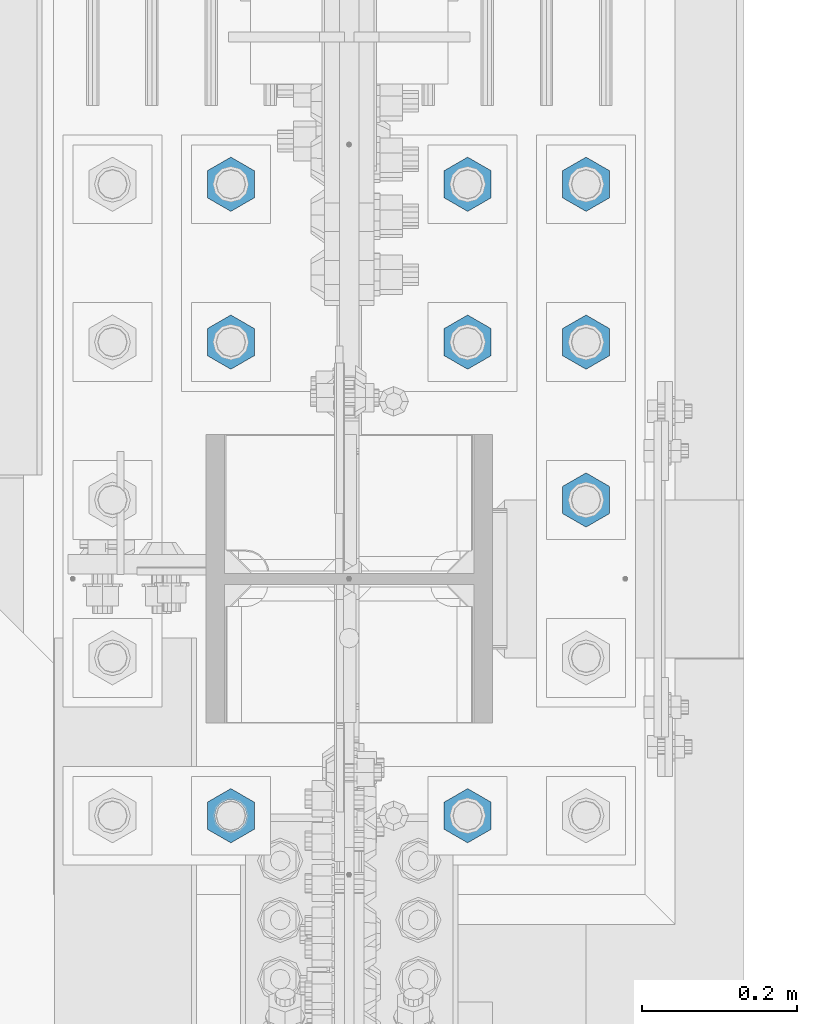
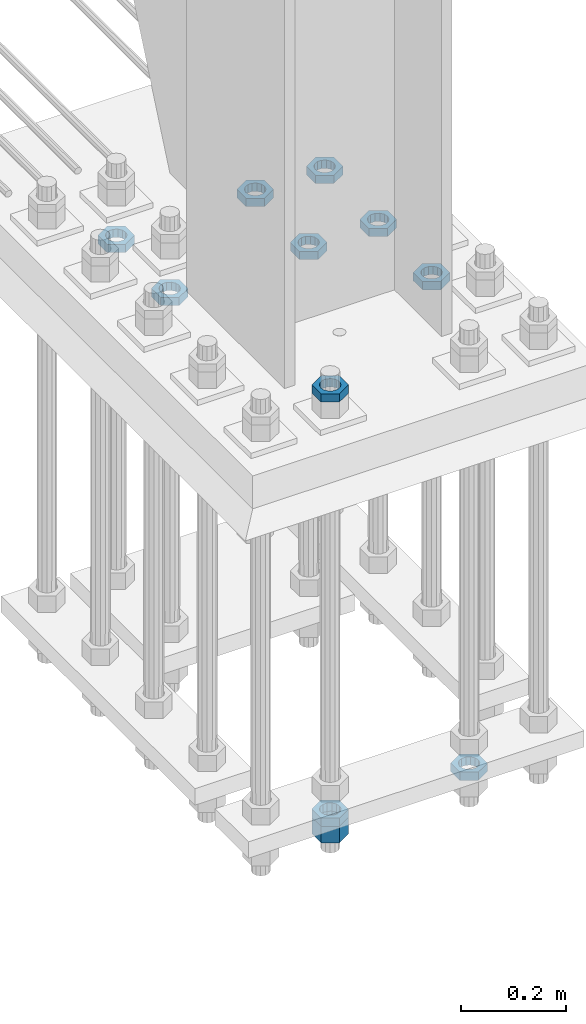
# One storey, part 2955 of 3843: 11 beams, 1 element without a shape of its own.
"""IFC2X3 building model written with IfcOpenShell, lengths in millimetres."""

from ifc_helpers import new_model, si_unit, frame, origin_with_axes, place, context, subcontext, project, spatial, faceted_brep, material, type_object, element, aggregate, save


model = new_model("IFC2X3")

# Units and contexts
model_context = context("Model", 3, precision=1e-05, world=origin_with_axes())
body_context = subcontext(model_context, "Body", "Model", "MODEL_VIEW")
ifc_project = project(units=[si_unit("LENGTHUNIT", "METRE", prefix="MILLI"), si_unit("AREAUNIT", "SQUARE_METRE"), si_unit("VOLUMEUNIT", "CUBIC_METRE"), si_unit("MASSUNIT", "GRAM", prefix="KILO"), si_unit("TIMEUNIT", "SECOND"), si_unit("PLANEANGLEUNIT", "RADIAN"), si_unit("SOLIDANGLEUNIT", "STERADIAN"), si_unit("THERMODYNAMICTEMPERATUREUNIT", "DEGREE_CELSIUS"), si_unit("LUMINOUSINTENSITYUNIT", "LUMEN")], contexts=[model_context])

# Site, building, storey
site_placement = place(None, origin_with_axes())
site = spatial("IfcSite", under=ifc_project, at=site_placement, CompositionType="ELEMENT")
building_placement = place(site_placement, origin_with_axes())
building = spatial("IfcBuilding", under=site, at=building_placement, Name="Undefined", CompositionType="ELEMENT")
storey_placement = place(building_placement, origin_with_axes())
storey = spatial("IfcBuildingStorey", under=building, at=storey_placement, Name="Undefined", CompositionType="ELEMENT", Elevation=0.0)

# Assembly, beams
assembly_placement = place(storey_placement, origin_with_axes())
assembly = element("IfcElementAssembly", 1, at=assembly_placement, inside=storey, Name="TEMPLATE", AssemblyPlace="NOTDEFINED", PredefinedType="RIGID_FRAME")
ifc_material = material(Name="STEEL/A572-50")
beam_type_1 = type_object("IfcBeamType", Name="1-1/2_HEAVY_HEX_NUT", PredefinedType="NOTDEFINED")
beam_1_placement = place(assembly_placement, frame((85496.4, 91909.9, 28746.4500015259), z_axis=(1.0, 0.0, 0.0), x_axis=(0.0, 0.0, -1.0)))
beam_1 = element("IfcBeam", 2, at=beam_1_placement, type_object=beam_type_1, material=ifc_material, Name="NUT", ObjectType="1-1/2_HEAVY_HEX_NUT", context=body_context, shape_type="Brep", body=[
    faceted_brep([(0.0, -34.9199981689453, 0.0), (0.0, -17.4599990844727, -30.25), (38.0999999999985, -17.4599990844727, -30.25), (38.0999999999985, -34.9199981689453, 0.0), (0.0, 17.4599990844727, -30.25), (38.0999999999985, 17.4599990844727, -30.25), (0.0, 34.9199981689453, 0.0), (38.0999999999985, 34.9199981689453, 0.0), (0.0, 17.4599990844727, 30.25), (38.0999999999985, 17.4599990844727, 30.25), (0.0, -17.4599990844727, 30.25), (38.0999999999985, -17.4599990844727, 30.25), (0.0, 0.0, 20.6399993896484), (0.0, 8.9553601105581, 18.5959968835959), (38.0999999999985, 8.9553601105581, 18.5959968835959), (38.0999999999985, 0.0, 20.6399993896484), (0.0, 16.1370013209525, 12.8688291298167), (38.0999999999985, 16.1370013209525, 12.8688291298167), (0.0, 20.1225115123816, 4.59283194104501), (38.0999999999985, 20.1225115123816, 4.59283194104501), (0.0, 20.1225115123816, -4.59283194104501), (38.0999999999985, 20.1225115123816, -4.59283194104501), (0.0, 16.1370013209525, -12.8688291298167), (38.0999999999985, 16.1370013209525, -12.8688291298167), (0.0, 8.9553601105581, -18.5959968835959), (38.0999999999985, 8.9553601105581, -18.5959968835959), (0.0, 0.0, -20.6399993896484), (38.0999999999985, 0.0, -20.6399993896484), (0.0, -8.9553601105581, -18.5959968835959), (38.0999999999985, -8.9553601105581, -18.5959968835959), (0.0, -16.1370013209525, -12.8688291298167), (38.0999999999985, -16.1370013209525, -12.8688291298167), (0.0, -20.1225115123816, -4.59283194104501), (38.0999999999985, -20.1225115123816, -4.59283194104501), (0.0, -20.1225115123816, 4.59283194104501), (38.0999999999985, -20.1225115123816, 4.59283194104501), (0.0, -16.1370013209525, 12.8688291298167), (38.0999999999985, -16.1370013209525, 12.8688291298167), (0.0, -8.9553601105581, 18.5959968835959), (38.0999999999985, -8.9553601105581, 18.5959968835959)], [[[0, 1, 2, 3]], [[1, 4, 5, 2]], [[4, 6, 7, 5]], [[6, 8, 9, 7]], [[8, 10, 11, 9]], [[10, 0, 3, 11]], [[12, 13, 14, 15]], [[13, 16, 17, 14]], [[16, 18, 19, 17]], [[18, 20, 21, 19]], [[20, 22, 23, 21]], [[22, 24, 25, 23]], [[24, 26, 27, 25]], [[26, 28, 29, 27]], [[28, 30, 31, 29]], [[30, 32, 33, 31]], [[32, 34, 35, 33]], [[34, 36, 37, 35]], [[36, 38, 39, 37]], [[38, 12, 15, 39]], [[5, 7, 9, 11, 3, 2], [17, 19, 21, 23, 25, 27, 29, 31, 33, 35, 37, 39, 15, 14]], [[10, 8, 6, 4, 1, 0], [38, 36, 34, 32, 30, 28, 26, 24, 22, 20, 18, 16, 13, 12]]]),
])
beam_type_2 = type_object("IfcBeamType", Name="1-1/2_HALF_NUT", PredefinedType="NOTDEFINED")
beam_2_placement = place(assembly_placement, frame((85953.5999938965, 92316.3, 29603.7), z_axis=(1.0, 0.0, 0.0), x_axis=(0.0, 0.0, -1.0)))
beam_2 = element("IfcBeam", 3, at=beam_2_placement, type_object=beam_type_2, material=ifc_material, Name="NUT", ObjectType="1-1/2_HALF_NUT", context=body_context, shape_type="Brep", body=[
    faceted_brep([(0.0, -34.9199981689453, 0.0), (0.0, -17.4599990844727, -30.25), (19.0500000000029, -17.4599990844727, -30.25), (19.0500000000029, -34.9199981689453, 0.0), (0.0, 17.4599990844727, -30.25), (19.0500000000029, 17.4599990844727, -30.25), (0.0, 34.9199981689453, 0.0), (19.0500000000029, 34.9199981689453, 0.0), (0.0, 17.4599990844727, 30.25), (19.0500000000029, 17.4599990844727, 30.25), (0.0, -17.4599990844727, 30.25), (19.0500000000029, -17.4599990844727, 30.25), (0.0, 0.0, 20.6399993896484), (0.0, 8.9553601105581, 18.5959968835959), (19.0500000000029, 8.95536011056538, 18.5959968835959), (19.0500000000029, 0.0, 20.6399993896484), (0.0, 16.1370013209525, 12.8688291298167), (19.0500000000029, 16.1370013209489, 12.8688291298167), (0.0, 20.1225115123816, 4.59283194104501), (19.0500000000029, 20.1225115123852, 4.59283194104501), (0.0, 20.1225115123816, -4.59283194104501), (19.0500000000029, 20.1225115123852, -4.59283194104501), (0.0, 16.1370013209525, -12.8688291298167), (19.0500000000029, 16.1370013209489, -12.8688291298167), (0.0, 8.9553601105581, -18.5959968835959), (19.0500000000029, 8.95536011056538, -18.5959968835959), (0.0, 0.0, -20.6399993896484), (19.0500000000029, 0.0, -20.6399993896484), (0.0, -8.9553601105581, -18.5959968835959), (19.0500000000029, -8.95536011056538, -18.5959968835959), (0.0, -16.1370013209525, -12.8688291298167), (19.0500000000029, -16.1370013209489, -12.8688291298167), (0.0, -20.1225115123816, -4.59283194104501), (19.0500000000029, -20.1225115123852, -4.59283194104501), (0.0, -20.1225115123816, 4.59283194104501), (19.0500000000029, -20.1225115123852, 4.59283194104501), (0.0, -16.1370013209525, 12.8688291298167), (19.0500000000029, -16.1370013209489, 12.8688291298167), (0.0, -8.9553601105581, 18.5959968835959), (19.0500000000029, -8.95536011056538, 18.5959968835959)], [[[0, 1, 2, 3]], [[1, 4, 5, 2]], [[4, 6, 7, 5]], [[6, 8, 9, 7]], [[8, 10, 11, 9]], [[10, 0, 3, 11]], [[12, 13, 14, 15]], [[13, 16, 17, 14]], [[16, 18, 19, 17]], [[18, 20, 21, 19]], [[20, 22, 23, 21]], [[22, 24, 25, 23]], [[24, 26, 27, 25]], [[26, 28, 29, 27]], [[28, 30, 31, 29]], [[30, 32, 33, 31]], [[32, 34, 35, 33]], [[34, 36, 37, 35]], [[36, 38, 39, 37]], [[38, 12, 15, 39]], [[5, 7, 9, 11, 3, 2], [17, 19, 21, 23, 25, 27, 29, 31, 33, 35, 37, 39, 15, 14]], [[10, 8, 6, 4, 1, 0], [38, 36, 34, 32, 30, 28, 26, 24, 22, 20, 18, 16, 13, 12]]]),
])
beam_3_placement = place(assembly_placement, frame((85953.5999938965, 92519.5, 29603.7), z_axis=(-1.0, 0.0, 0.0), x_axis=(0.0, 0.0, -1.0)))
beam_3 = element("IfcBeam", 4, at=beam_3_placement, type_object=beam_type_2, material=ifc_material, Name="NUT", ObjectType="1-1/2_HALF_NUT", context=body_context, shape_type="Brep", body=[
    faceted_brep([(0.0, -34.9199981689453, 0.0), (0.0, -17.4599990844727, -30.25), (19.0500000000029, -17.4599990844727, -30.25), (19.0500000000029, -34.9199981689453, 0.0), (0.0, 17.4599990844727, -30.25), (19.0500000000029, 17.4599990844727, -30.25), (0.0, 34.9199981689453, 0.0), (19.0500000000029, 34.9199981689453, 0.0), (0.0, 17.4599990844727, 30.25), (19.0500000000029, 17.4599990844727, 30.25), (0.0, -17.4599990844727, 30.25), (19.0500000000029, -17.4599990844727, 30.25), (0.0, 0.0, 20.6399993896484), (0.0, 8.9553601105581, 18.5959968835959), (19.0500000000029, 8.95536011056538, 18.5959968835959), (19.0500000000029, 0.0, 20.6399993896484), (0.0, 16.1370013209525, 12.8688291298167), (19.0500000000029, 16.1370013209489, 12.8688291298167), (0.0, 20.1225115123816, 4.59283194104501), (19.0500000000029, 20.1225115123852, 4.59283194104501), (0.0, 20.1225115123816, -4.59283194104501), (19.0500000000029, 20.1225115123852, -4.59283194104501), (0.0, 16.1370013209525, -12.8688291298167), (19.0500000000029, 16.1370013209489, -12.8688291298167), (0.0, 8.9553601105581, -18.5959968835959), (19.0500000000029, 8.95536011056538, -18.5959968835959), (0.0, 0.0, -20.6399993896484), (19.0500000000029, 0.0, -20.6399993896484), (0.0, -8.9553601105581, -18.5959968835959), (19.0500000000029, -8.95536011056538, -18.5959968835959), (0.0, -16.1370013209525, -12.8688291298167), (19.0500000000029, -16.1370013209489, -12.8688291298167), (0.0, -20.1225115123816, -4.59283194104501), (19.0500000000029, -20.1225115123852, -4.59283194104501), (0.0, -20.1225115123816, 4.59283194104501), (19.0500000000029, -20.1225115123852, 4.59283194104501), (0.0, -16.1370013209525, 12.8688291298167), (19.0500000000029, -16.1370013209489, 12.8688291298167), (0.0, -8.9553601105581, 18.5959968835959), (19.0500000000029, -8.95536011056538, 18.5959968835959)], [[[0, 1, 2, 3]], [[1, 4, 5, 2]], [[4, 6, 7, 5]], [[6, 8, 9, 7]], [[8, 10, 11, 9]], [[10, 0, 3, 11]], [[12, 13, 14, 15]], [[13, 16, 17, 14]], [[16, 18, 19, 17]], [[18, 20, 21, 19]], [[20, 22, 23, 21]], [[22, 24, 25, 23]], [[24, 26, 27, 25]], [[26, 28, 29, 27]], [[28, 30, 31, 29]], [[30, 32, 33, 31]], [[32, 34, 35, 33]], [[34, 36, 37, 35]], [[36, 38, 39, 37]], [[38, 12, 15, 39]], [[5, 7, 9, 11, 3, 2], [17, 19, 21, 23, 25, 27, 29, 31, 33, 35, 37, 39, 15, 14]], [[10, 8, 6, 4, 1, 0], [38, 36, 34, 32, 30, 28, 26, 24, 22, 20, 18, 16, 13, 12]]]),
])
beam_4_placement = place(assembly_placement, frame((85953.5999938965, 92722.7, 29603.7), z_axis=(-1.0, 0.0, 0.0), x_axis=(0.0, 0.0, -1.0)))
beam_4 = element("IfcBeam", 5, at=beam_4_placement, type_object=beam_type_2, material=ifc_material, Name="NUT", ObjectType="1-1/2_HALF_NUT", context=body_context, shape_type="Brep", body=[
    faceted_brep([(0.0, -34.9199981689453, 0.0), (0.0, -17.4599990844727, -30.25), (19.0500000000029, -17.4599990844727, -30.25), (19.0500000000029, -34.9199981689453, 0.0), (0.0, 17.4599990844727, -30.25), (19.0500000000029, 17.4599990844727, -30.25), (0.0, 34.9199981689453, 0.0), (19.0500000000029, 34.9199981689453, 0.0), (0.0, 17.4599990844727, 30.25), (19.0500000000029, 17.4599990844727, 30.25), (0.0, -17.4599990844727, 30.25), (19.0500000000029, -17.4599990844727, 30.25), (0.0, 0.0, 20.6399993896484), (0.0, 8.9553601105581, 18.5959968835959), (19.0500000000029, 8.95536011056538, 18.5959968835959), (19.0500000000029, 0.0, 20.6399993896484), (0.0, 16.1370013209525, 12.8688291298167), (19.0500000000029, 16.1370013209489, 12.8688291298167), (0.0, 20.1225115123816, 4.59283194104501), (19.0500000000029, 20.1225115123852, 4.59283194104501), (0.0, 20.1225115123816, -4.59283194104501), (19.0500000000029, 20.1225115123852, -4.59283194104501), (0.0, 16.1370013209525, -12.8688291298167), (19.0500000000029, 16.1370013209489, -12.8688291298167), (0.0, 8.9553601105581, -18.5959968835959), (19.0500000000029, 8.95536011056538, -18.5959968835959), (0.0, 0.0, -20.6399993896484), (19.0500000000029, 0.0, -20.6399993896484), (0.0, -8.9553601105581, -18.5959968835959), (19.0500000000029, -8.95536011056538, -18.5959968835959), (0.0, -16.1370013209525, -12.8688291298167), (19.0500000000029, -16.1370013209489, -12.8688291298167), (0.0, -20.1225115123816, -4.59283194104501), (19.0500000000029, -20.1225115123852, -4.59283194104501), (0.0, -20.1225115123816, 4.59283194104501), (19.0500000000029, -20.1225115123852, 4.59283194104501), (0.0, -16.1370013209525, 12.8688291298167), (19.0500000000029, -16.1370013209489, 12.8688291298167), (0.0, -8.9553601105581, 18.5959968835959), (19.0500000000029, -8.95536011056538, 18.5959968835959)], [[[0, 1, 2, 3]], [[1, 4, 5, 2]], [[4, 6, 7, 5]], [[6, 8, 9, 7]], [[8, 10, 11, 9]], [[10, 0, 3, 11]], [[12, 13, 14, 15]], [[13, 16, 17, 14]], [[16, 18, 19, 17]], [[18, 20, 21, 19]], [[20, 22, 23, 21]], [[22, 24, 25, 23]], [[24, 26, 27, 25]], [[26, 28, 29, 27]], [[28, 30, 31, 29]], [[30, 32, 33, 31]], [[32, 34, 35, 33]], [[34, 36, 37, 35]], [[36, 38, 39, 37]], [[38, 12, 15, 39]], [[5, 7, 9, 11, 3, 2], [17, 19, 21, 23, 25, 27, 29, 31, 33, 35, 37, 39, 15, 14]], [[10, 8, 6, 4, 1, 0], [38, 36, 34, 32, 30, 28, 26, 24, 22, 20, 18, 16, 13, 12]]]),
])
beam_5_placement = place(assembly_placement, frame((85496.3999938965, 92722.7, 29603.7), z_axis=(-1.0, 0.0, 0.0), x_axis=(0.0, 0.0, -1.0)))
beam_5 = element("IfcBeam", 6, at=beam_5_placement, type_object=beam_type_2, material=ifc_material, Name="NUT", ObjectType="1-1/2_HALF_NUT", context=body_context, shape_type="Brep", body=[
    faceted_brep([(0.0, -34.9199981689453, 0.0), (0.0, -17.4599990844727, -30.25), (19.0500000000029, -17.4599990844727, -30.25), (19.0500000000029, -34.9199981689453, 0.0), (0.0, 17.4599990844727, -30.25), (19.0500000000029, 17.4599990844727, -30.25), (0.0, 34.9199981689453, 0.0), (19.0500000000029, 34.9199981689453, 0.0), (0.0, 17.4599990844727, 30.25), (19.0500000000029, 17.4599990844727, 30.25), (0.0, -17.4599990844727, 30.25), (19.0500000000029, -17.4599990844727, 30.25), (0.0, 0.0, 20.6399993896484), (0.0, 8.9553601105581, 18.5959968835959), (19.0500000000029, 8.95536011056538, 18.5959968835959), (19.0500000000029, 0.0, 20.6399993896484), (0.0, 16.1370013209525, 12.8688291298167), (19.0500000000029, 16.1370013209489, 12.8688291298167), (0.0, 20.1225115123816, 4.59283194104501), (19.0500000000029, 20.1225115123852, 4.59283194104501), (0.0, 20.1225115123816, -4.59283194104501), (19.0500000000029, 20.1225115123852, -4.59283194104501), (0.0, 16.1370013209525, -12.8688291298167), (19.0500000000029, 16.1370013209489, -12.8688291298167), (0.0, 8.9553601105581, -18.5959968835959), (19.0500000000029, 8.95536011056538, -18.5959968835959), (0.0, 0.0, -20.6399993896484), (19.0500000000029, 0.0, -20.6399993896484), (0.0, -8.9553601105581, -18.5959968835959), (19.0500000000029, -8.95536011056538, -18.5959968835959), (0.0, -16.1370013209525, -12.8688291298167), (19.0500000000029, -16.1370013209489, -12.8688291298167), (0.0, -20.1225115123816, -4.59283194104501), (19.0500000000029, -20.1225115123852, -4.59283194104501), (0.0, -20.1225115123816, 4.59283194104501), (19.0500000000029, -20.1225115123852, 4.59283194104501), (0.0, -16.1370013209525, 12.8688291298167), (19.0500000000029, -16.1370013209489, 12.8688291298167), (0.0, -8.9553601105581, 18.5959968835959), (19.0500000000029, -8.95536011056538, 18.5959968835959)], [[[0, 1, 2, 3]], [[1, 4, 5, 2]], [[4, 6, 7, 5]], [[6, 8, 9, 7]], [[8, 10, 11, 9]], [[10, 0, 3, 11]], [[12, 13, 14, 15]], [[13, 16, 17, 14]], [[16, 18, 19, 17]], [[18, 20, 21, 19]], [[20, 22, 23, 21]], [[22, 24, 25, 23]], [[24, 26, 27, 25]], [[26, 28, 29, 27]], [[28, 30, 31, 29]], [[30, 32, 33, 31]], [[32, 34, 35, 33]], [[34, 36, 37, 35]], [[36, 38, 39, 37]], [[38, 12, 15, 39]], [[5, 7, 9, 11, 3, 2], [17, 19, 21, 23, 25, 27, 29, 31, 33, 35, 37, 39, 15, 14]], [[10, 8, 6, 4, 1, 0], [38, 36, 34, 32, 30, 28, 26, 24, 22, 20, 18, 16, 13, 12]]]),
])
beam_6_placement = place(assembly_placement, frame((85801.1999938965, 92722.7, 29603.7), z_axis=(-1.0, 0.0, 0.0), x_axis=(0.0, 0.0, -1.0)))
beam_6 = element("IfcBeam", 7, at=beam_6_placement, type_object=beam_type_2, material=ifc_material, Name="NUT", ObjectType="1-1/2_HALF_NUT", context=body_context, shape_type="Brep", body=[
    faceted_brep([(0.0, -34.9199981689453, 0.0), (0.0, -17.4599990844727, -30.25), (19.0500000000029, -17.4599990844727, -30.25), (19.0500000000029, -34.9199981689453, 0.0), (0.0, 17.4599990844727, -30.25), (19.0500000000029, 17.4599990844727, -30.25), (0.0, 34.9199981689453, 0.0), (19.0500000000029, 34.9199981689453, 0.0), (0.0, 17.4599990844727, 30.25), (19.0500000000029, 17.4599990844727, 30.25), (0.0, -17.4599990844727, 30.25), (19.0500000000029, -17.4599990844727, 30.25), (0.0, 0.0, 20.6399993896484), (0.0, 8.9553601105581, 18.5959968835959), (19.0500000000029, 8.95536011056538, 18.5959968835959), (19.0500000000029, 0.0, 20.6399993896484), (0.0, 16.1370013209525, 12.8688291298167), (19.0500000000029, 16.1370013209489, 12.8688291298167), (0.0, 20.1225115123816, 4.59283194104501), (19.0500000000029, 20.1225115123852, 4.59283194104501), (0.0, 20.1225115123816, -4.59283194104501), (19.0500000000029, 20.1225115123852, -4.59283194104501), (0.0, 16.1370013209525, -12.8688291298167), (19.0500000000029, 16.1370013209489, -12.8688291298167), (0.0, 8.9553601105581, -18.5959968835959), (19.0500000000029, 8.95536011056538, -18.5959968835959), (0.0, 0.0, -20.6399993896484), (19.0500000000029, 0.0, -20.6399993896484), (0.0, -8.9553601105581, -18.5959968835959), (19.0500000000029, -8.95536011056538, -18.5959968835959), (0.0, -16.1370013209525, -12.8688291298167), (19.0500000000029, -16.1370013209489, -12.8688291298167), (0.0, -20.1225115123816, -4.59283194104501), (19.0500000000029, -20.1225115123852, -4.59283194104501), (0.0, -20.1225115123816, 4.59283194104501), (19.0500000000029, -20.1225115123852, 4.59283194104501), (0.0, -16.1370013209525, 12.8688291298167), (19.0500000000029, -16.1370013209489, 12.8688291298167), (0.0, -8.9553601105581, 18.5959968835959), (19.0500000000029, -8.95536011056538, 18.5959968835959)], [[[0, 1, 2, 3]], [[1, 4, 5, 2]], [[4, 6, 7, 5]], [[6, 8, 9, 7]], [[8, 10, 11, 9]], [[10, 0, 3, 11]], [[12, 13, 14, 15]], [[13, 16, 17, 14]], [[16, 18, 19, 17]], [[18, 20, 21, 19]], [[20, 22, 23, 21]], [[22, 24, 25, 23]], [[24, 26, 27, 25]], [[26, 28, 29, 27]], [[28, 30, 31, 29]], [[30, 32, 33, 31]], [[32, 34, 35, 33]], [[34, 36, 37, 35]], [[36, 38, 39, 37]], [[38, 12, 15, 39]], [[5, 7, 9, 11, 3, 2], [17, 19, 21, 23, 25, 27, 29, 31, 33, 35, 37, 39, 15, 14]], [[10, 8, 6, 4, 1, 0], [38, 36, 34, 32, 30, 28, 26, 24, 22, 20, 18, 16, 13, 12]]]),
])
beam_7_placement = place(assembly_placement, frame((85496.3999938965, 92519.5, 29603.7), z_axis=(-1.0, 0.0, 0.0), x_axis=(0.0, 0.0, -1.0)))
beam_7 = element("IfcBeam", 8, at=beam_7_placement, type_object=beam_type_2, material=ifc_material, Name="NUT", ObjectType="1-1/2_HALF_NUT", context=body_context, shape_type="Brep", body=[
    faceted_brep([(0.0, -34.9199981689453, 0.0), (0.0, -17.4599990844727, -30.25), (19.0500000000029, -17.4599990844727, -30.25), (19.0500000000029, -34.9199981689453, 0.0), (0.0, 17.4599990844727, -30.25), (19.0500000000029, 17.4599990844727, -30.25), (0.0, 34.9199981689453, 0.0), (19.0500000000029, 34.9199981689453, 0.0), (0.0, 17.4599990844727, 30.25), (19.0500000000029, 17.4599990844727, 30.25), (0.0, -17.4599990844727, 30.25), (19.0500000000029, -17.4599990844727, 30.25), (0.0, 0.0, 20.6399993896484), (0.0, 8.9553601105581, 18.5959968835959), (19.0500000000029, 8.95536011056538, 18.5959968835959), (19.0500000000029, 0.0, 20.6399993896484), (0.0, 16.1370013209525, 12.8688291298167), (19.0500000000029, 16.1370013209489, 12.8688291298167), (0.0, 20.1225115123816, 4.59283194104501), (19.0500000000029, 20.1225115123852, 4.59283194104501), (0.0, 20.1225115123816, -4.59283194104501), (19.0500000000029, 20.1225115123852, -4.59283194104501), (0.0, 16.1370013209525, -12.8688291298167), (19.0500000000029, 16.1370013209489, -12.8688291298167), (0.0, 8.9553601105581, -18.5959968835959), (19.0500000000029, 8.95536011056538, -18.5959968835959), (0.0, 0.0, -20.6399993896484), (19.0500000000029, 0.0, -20.6399993896484), (0.0, -8.9553601105581, -18.5959968835959), (19.0500000000029, -8.95536011056538, -18.5959968835959), (0.0, -16.1370013209525, -12.8688291298167), (19.0500000000029, -16.1370013209489, -12.8688291298167), (0.0, -20.1225115123816, -4.59283194104501), (19.0500000000029, -20.1225115123852, -4.59283194104501), (0.0, -20.1225115123816, 4.59283194104501), (19.0500000000029, -20.1225115123852, 4.59283194104501), (0.0, -16.1370013209525, 12.8688291298167), (19.0500000000029, -16.1370013209489, 12.8688291298167), (0.0, -8.9553601105581, 18.5959968835959), (19.0500000000029, -8.95536011056538, 18.5959968835959)], [[[0, 1, 2, 3]], [[1, 4, 5, 2]], [[4, 6, 7, 5]], [[6, 8, 9, 7]], [[8, 10, 11, 9]], [[10, 0, 3, 11]], [[12, 13, 14, 15]], [[13, 16, 17, 14]], [[16, 18, 19, 17]], [[18, 20, 21, 19]], [[20, 22, 23, 21]], [[22, 24, 25, 23]], [[24, 26, 27, 25]], [[26, 28, 29, 27]], [[28, 30, 31, 29]], [[30, 32, 33, 31]], [[32, 34, 35, 33]], [[34, 36, 37, 35]], [[36, 38, 39, 37]], [[38, 12, 15, 39]], [[5, 7, 9, 11, 3, 2], [17, 19, 21, 23, 25, 27, 29, 31, 33, 35, 37, 39, 15, 14]], [[10, 8, 6, 4, 1, 0], [38, 36, 34, 32, 30, 28, 26, 24, 22, 20, 18, 16, 13, 12]]]),
])
beam_8_placement = place(assembly_placement, frame((85801.1999938965, 92519.5, 29603.7), z_axis=(-1.0, 0.0, 0.0), x_axis=(0.0, 0.0, -1.0)))
beam_8 = element("IfcBeam", 9, at=beam_8_placement, type_object=beam_type_2, material=ifc_material, Name="NUT", ObjectType="1-1/2_HALF_NUT", context=body_context, shape_type="Brep", body=[
    faceted_brep([(0.0, -34.9199981689453, 0.0), (0.0, -17.4599990844727, -30.25), (19.0500000000029, -17.4599990844727, -30.25), (19.0500000000029, -34.9199981689453, 0.0), (0.0, 17.4599990844727, -30.25), (19.0500000000029, 17.4599990844727, -30.25), (0.0, 34.9199981689453, 0.0), (19.0500000000029, 34.9199981689453, 0.0), (0.0, 17.4599990844727, 30.25), (19.0500000000029, 17.4599990844727, 30.25), (0.0, -17.4599990844727, 30.25), (19.0500000000029, -17.4599990844727, 30.25), (0.0, 0.0, 20.6399993896484), (0.0, 8.9553601105581, 18.5959968835959), (19.0500000000029, 8.95536011056538, 18.5959968835959), (19.0500000000029, 0.0, 20.6399993896484), (0.0, 16.1370013209525, 12.8688291298167), (19.0500000000029, 16.1370013209489, 12.8688291298167), (0.0, 20.1225115123816, 4.59283194104501), (19.0500000000029, 20.1225115123852, 4.59283194104501), (0.0, 20.1225115123816, -4.59283194104501), (19.0500000000029, 20.1225115123852, -4.59283194104501), (0.0, 16.1370013209525, -12.8688291298167), (19.0500000000029, 16.1370013209489, -12.8688291298167), (0.0, 8.9553601105581, -18.5959968835959), (19.0500000000029, 8.95536011056538, -18.5959968835959), (0.0, 0.0, -20.6399993896484), (19.0500000000029, 0.0, -20.6399993896484), (0.0, -8.9553601105581, -18.5959968835959), (19.0500000000029, -8.95536011056538, -18.5959968835959), (0.0, -16.1370013209525, -12.8688291298167), (19.0500000000029, -16.1370013209489, -12.8688291298167), (0.0, -20.1225115123816, -4.59283194104501), (19.0500000000029, -20.1225115123852, -4.59283194104501), (0.0, -20.1225115123816, 4.59283194104501), (19.0500000000029, -20.1225115123852, 4.59283194104501), (0.0, -16.1370013209525, 12.8688291298167), (19.0500000000029, -16.1370013209489, 12.8688291298167), (0.0, -8.9553601105581, 18.5959968835959), (19.0500000000029, -8.95536011056538, 18.5959968835959)], [[[0, 1, 2, 3]], [[1, 4, 5, 2]], [[4, 6, 7, 5]], [[6, 8, 9, 7]], [[8, 10, 11, 9]], [[10, 0, 3, 11]], [[12, 13, 14, 15]], [[13, 16, 17, 14]], [[16, 18, 19, 17]], [[18, 20, 21, 19]], [[20, 22, 23, 21]], [[22, 24, 25, 23]], [[24, 26, 27, 25]], [[26, 28, 29, 27]], [[28, 30, 31, 29]], [[30, 32, 33, 31]], [[32, 34, 35, 33]], [[34, 36, 37, 35]], [[36, 38, 39, 37]], [[38, 12, 15, 39]], [[5, 7, 9, 11, 3, 2], [17, 19, 21, 23, 25, 27, 29, 31, 33, 35, 37, 39, 15, 14]], [[10, 8, 6, 4, 1, 0], [38, 36, 34, 32, 30, 28, 26, 24, 22, 20, 18, 16, 13, 12]]]),
])
beam_9_placement = place(assembly_placement, frame((85496.4, 91909.9, 28765.5000015259), z_axis=(1.0, 0.0, 0.0), x_axis=(0.0, 0.0, -1.0)))
beam_9 = element("IfcBeam", 10, at=beam_9_placement, type_object=beam_type_2, material=ifc_material, Name="NUT", ObjectType="1-1/2_HALF_NUT", context=body_context, shape_type="Brep", body=[
    faceted_brep([(0.0, -34.9199981689453, 0.0), (0.0, -17.4599990844727, -30.25), (19.0500000000029, -17.4599990844727, -30.25), (19.0500000000029, -34.9199981689453, 0.0), (0.0, 17.4599990844727, -30.25), (19.0500000000029, 17.4599990844727, -30.25), (0.0, 34.9199981689453, 0.0), (19.0500000000029, 34.9199981689453, 0.0), (0.0, 17.4599990844727, 30.25), (19.0500000000029, 17.4599990844727, 30.25), (0.0, -17.4599990844727, 30.25), (19.0500000000029, -17.4599990844727, 30.25), (0.0, 0.0, 20.6399993896484), (0.0, 8.9553601105581, 18.5959968835959), (19.0500000000029, 8.95536011056538, 18.5959968835959), (19.0500000000029, 0.0, 20.6399993896484), (0.0, 16.1370013209525, 12.8688291298167), (19.0500000000029, 16.1370013209489, 12.8688291298167), (0.0, 20.1225115123816, 4.59283194104501), (19.0500000000029, 20.1225115123852, 4.59283194104501), (0.0, 20.1225115123816, -4.59283194104501), (19.0500000000029, 20.1225115123852, -4.59283194104501), (0.0, 16.1370013209525, -12.8688291298167), (19.0500000000029, 16.1370013209489, -12.8688291298167), (0.0, 8.9553601105581, -18.5959968835959), (19.0500000000029, 8.95536011056538, -18.5959968835959), (0.0, 0.0, -20.6399993896484), (19.0500000000029, 0.0, -20.6399993896484), (0.0, -8.9553601105581, -18.5959968835959), (19.0500000000029, -8.95536011056538, -18.5959968835959), (0.0, -16.1370013209525, -12.8688291298167), (19.0500000000029, -16.1370013209489, -12.8688291298167), (0.0, -20.1225115123816, -4.59283194104501), (19.0500000000029, -20.1225115123852, -4.59283194104501), (0.0, -20.1225115123816, 4.59283194104501), (19.0500000000029, -20.1225115123852, 4.59283194104501), (0.0, -16.1370013209525, 12.8688291298167), (19.0500000000029, -16.1370013209489, 12.8688291298167), (0.0, -8.9553601105581, 18.5959968835959), (19.0500000000029, -8.95536011056538, 18.5959968835959)], [[[0, 1, 2, 3]], [[1, 4, 5, 2]], [[4, 6, 7, 5]], [[6, 8, 9, 7]], [[8, 10, 11, 9]], [[10, 0, 3, 11]], [[12, 13, 14, 15]], [[13, 16, 17, 14]], [[16, 18, 19, 17]], [[18, 20, 21, 19]], [[20, 22, 23, 21]], [[22, 24, 25, 23]], [[24, 26, 27, 25]], [[26, 28, 29, 27]], [[28, 30, 31, 29]], [[30, 32, 33, 31]], [[32, 34, 35, 33]], [[34, 36, 37, 35]], [[36, 38, 39, 37]], [[38, 12, 15, 39]], [[5, 7, 9, 11, 3, 2], [17, 19, 21, 23, 25, 27, 29, 31, 33, 35, 37, 39, 15, 14]], [[10, 8, 6, 4, 1, 0], [38, 36, 34, 32, 30, 28, 26, 24, 22, 20, 18, 16, 13, 12]]]),
])
beam_10_placement = place(assembly_placement, frame((85496.4, 91909.9, 29749.75), z_axis=(1.0, 0.0, 0.0), x_axis=(0.0, 0.0, -1.0)))
beam_10 = element("IfcBeam", 11, at=beam_10_placement, type_object=beam_type_2, material=ifc_material, Name="NUT", ObjectType="1-1/2_HALF_NUT", context=body_context, shape_type="Brep", body=[
    faceted_brep([(0.0, -34.9199981689453, 0.0), (0.0, -17.4599990844727, -30.25), (19.0500000000029, -17.4599990844727, -30.25), (19.0500000000029, -34.9199981689453, 0.0), (0.0, 17.4599990844727, -30.25), (19.0500000000029, 17.4599990844727, -30.25), (0.0, 34.9199981689453, 0.0), (19.0500000000029, 34.9199981689453, 0.0), (0.0, 17.4599990844727, 30.25), (19.0500000000029, 17.4599990844727, 30.25), (0.0, -17.4599990844727, 30.25), (19.0500000000029, -17.4599990844727, 30.25), (0.0, 0.0, 20.6399993896484), (0.0, 8.9553601105581, 18.5959968835959), (19.0500000000029, 8.95536011056538, 18.5959968835959), (19.0500000000029, 0.0, 20.6399993896484), (0.0, 16.1370013209525, 12.8688291298167), (19.0500000000029, 16.1370013209489, 12.8688291298167), (0.0, 20.1225115123816, 4.59283194104501), (19.0500000000029, 20.1225115123852, 4.59283194104501), (0.0, 20.1225115123816, -4.59283194104501), (19.0500000000029, 20.1225115123852, -4.59283194104501), (0.0, 16.1370013209525, -12.8688291298167), (19.0500000000029, 16.1370013209489, -12.8688291298167), (0.0, 8.9553601105581, -18.5959968835959), (19.0500000000029, 8.95536011056538, -18.5959968835959), (0.0, 0.0, -20.6399993896484), (19.0500000000029, 0.0, -20.6399993896484), (0.0, -8.9553601105581, -18.5959968835959), (19.0500000000029, -8.95536011056538, -18.5959968835959), (0.0, -16.1370013209525, -12.8688291298167), (19.0500000000029, -16.1370013209489, -12.8688291298167), (0.0, -20.1225115123816, -4.59283194104501), (19.0500000000029, -20.1225115123852, -4.59283194104501), (0.0, -20.1225115123816, 4.59283194104501), (19.0500000000029, -20.1225115123852, 4.59283194104501), (0.0, -16.1370013209525, 12.8688291298167), (19.0500000000029, -16.1370013209489, 12.8688291298167), (0.0, -8.9553601105581, 18.5959968835959), (19.0500000000029, -8.95536011056538, 18.5959968835959)], [[[0, 1, 2, 3]], [[1, 4, 5, 2]], [[4, 6, 7, 5]], [[6, 8, 9, 7]], [[8, 10, 11, 9]], [[10, 0, 3, 11]], [[12, 13, 14, 15]], [[13, 16, 17, 14]], [[16, 18, 19, 17]], [[18, 20, 21, 19]], [[20, 22, 23, 21]], [[22, 24, 25, 23]], [[24, 26, 27, 25]], [[26, 28, 29, 27]], [[28, 30, 31, 29]], [[30, 32, 33, 31]], [[32, 34, 35, 33]], [[34, 36, 37, 35]], [[36, 38, 39, 37]], [[38, 12, 15, 39]], [[5, 7, 9, 11, 3, 2], [17, 19, 21, 23, 25, 27, 29, 31, 33, 35, 37, 39, 15, 14]], [[10, 8, 6, 4, 1, 0], [38, 36, 34, 32, 30, 28, 26, 24, 22, 20, 18, 16, 13, 12]]]),
])
beam_11_placement = place(assembly_placement, frame((85801.2, 91909.9, 28765.5000015259), z_axis=(1.0, 0.0, 0.0), x_axis=(0.0, 0.0, -1.0)))
beam_11 = element("IfcBeam", 12, at=beam_11_placement, type_object=beam_type_2, material=ifc_material, Name="NUT", ObjectType="1-1/2_HALF_NUT", context=body_context, shape_type="Brep", body=[
    faceted_brep([(0.0, -34.9199981689453, 0.0), (0.0, -17.4599990844727, -30.25), (19.0500000000029, -17.4599990844727, -30.25), (19.0500000000029, -34.9199981689453, 0.0), (0.0, 17.4599990844727, -30.25), (19.0500000000029, 17.4599990844727, -30.25), (0.0, 34.9199981689453, 0.0), (19.0500000000029, 34.9199981689453, 0.0), (0.0, 17.4599990844727, 30.25), (19.0500000000029, 17.4599990844727, 30.25), (0.0, -17.4599990844727, 30.25), (19.0500000000029, -17.4599990844727, 30.25), (0.0, 0.0, 20.6399993896484), (0.0, 8.9553601105581, 18.5959968835959), (19.0500000000029, 8.95536011056538, 18.5959968835959), (19.0500000000029, 0.0, 20.6399993896484), (0.0, 16.1370013209525, 12.8688291298167), (19.0500000000029, 16.1370013209489, 12.8688291298167), (0.0, 20.1225115123816, 4.59283194104501), (19.0500000000029, 20.1225115123852, 4.59283194104501), (0.0, 20.1225115123816, -4.59283194104501), (19.0500000000029, 20.1225115123852, -4.59283194104501), (0.0, 16.1370013209525, -12.8688291298167), (19.0500000000029, 16.1370013209489, -12.8688291298167), (0.0, 8.9553601105581, -18.5959968835959), (19.0500000000029, 8.95536011056538, -18.5959968835959), (0.0, 0.0, -20.6399993896484), (19.0500000000029, 0.0, -20.6399993896484), (0.0, -8.9553601105581, -18.5959968835959), (19.0500000000029, -8.95536011056538, -18.5959968835959), (0.0, -16.1370013209525, -12.8688291298167), (19.0500000000029, -16.1370013209489, -12.8688291298167), (0.0, -20.1225115123816, -4.59283194104501), (19.0500000000029, -20.1225115123852, -4.59283194104501), (0.0, -20.1225115123816, 4.59283194104501), (19.0500000000029, -20.1225115123852, 4.59283194104501), (0.0, -16.1370013209525, 12.8688291298167), (19.0500000000029, -16.1370013209489, 12.8688291298167), (0.0, -8.9553601105581, 18.5959968835959), (19.0500000000029, -8.95536011056538, 18.5959968835959)], [[[0, 1, 2, 3]], [[1, 4, 5, 2]], [[4, 6, 7, 5]], [[6, 8, 9, 7]], [[8, 10, 11, 9]], [[10, 0, 3, 11]], [[12, 13, 14, 15]], [[13, 16, 17, 14]], [[16, 18, 19, 17]], [[18, 20, 21, 19]], [[20, 22, 23, 21]], [[22, 24, 25, 23]], [[24, 26, 27, 25]], [[26, 28, 29, 27]], [[28, 30, 31, 29]], [[30, 32, 33, 31]], [[32, 34, 35, 33]], [[34, 36, 37, 35]], [[36, 38, 39, 37]], [[38, 12, 15, 39]], [[5, 7, 9, 11, 3, 2], [17, 19, 21, 23, 25, 27, 29, 31, 33, 35, 37, 39, 15, 14]], [[10, 8, 6, 4, 1, 0], [38, 36, 34, 32, 30, 28, 26, 24, 22, 20, 18, 16, 13, 12]]]),
])
aggregate(assembly, [beam_2, beam_3, beam_4, beam_5, beam_6, beam_7, beam_8, beam_9, beam_1, beam_10, beam_11])

save(model, "model.ifc")
